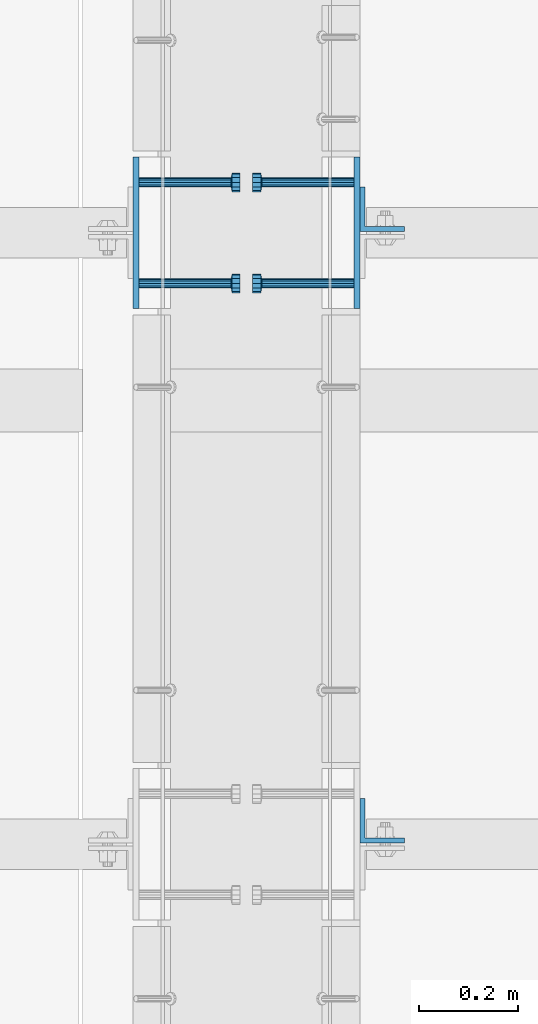
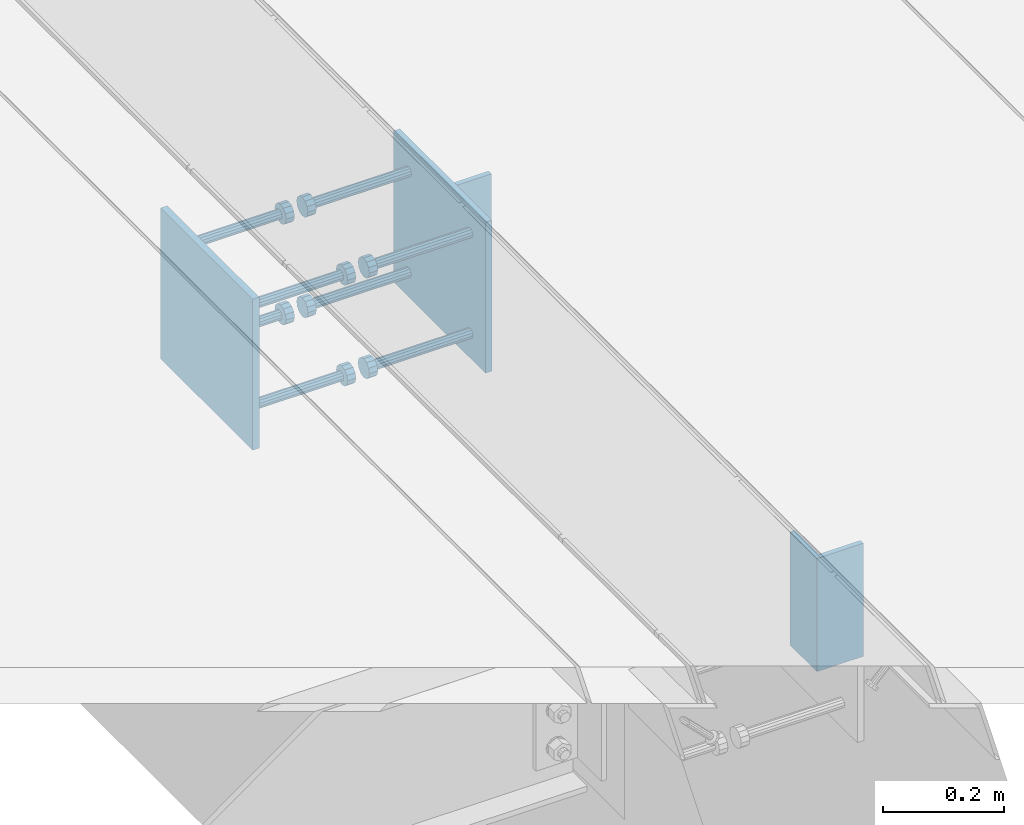
# One storey, part 2082 of 3843: 12 beams, 4 elements without a shape of their own.
"""IFC2X3 building model written with IfcOpenShell, lengths in millimetres."""

from ifc_helpers import new_model, si_unit, frame, origin_with_axes, place, context, subcontext, project, spatial, faceted_brep, material, type_object, element, aggregate, save


model = new_model("IFC2X3")

# Units and contexts
model_context = context("Model", 3, precision=1e-05, world=origin_with_axes())
body_context = subcontext(model_context, "Body", "Model", "MODEL_VIEW")
ifc_project = project(units=[si_unit("LENGTHUNIT", "METRE", prefix="MILLI"), si_unit("AREAUNIT", "SQUARE_METRE"), si_unit("VOLUMEUNIT", "CUBIC_METRE"), si_unit("MASSUNIT", "GRAM", prefix="KILO"), si_unit("TIMEUNIT", "SECOND"), si_unit("PLANEANGLEUNIT", "RADIAN"), si_unit("SOLIDANGLEUNIT", "STERADIAN"), si_unit("THERMODYNAMICTEMPERATUREUNIT", "DEGREE_CELSIUS"), si_unit("LUMINOUSINTENSITYUNIT", "LUMEN")], contexts=[model_context])

# Site, building, storey
site_placement = place(None, origin_with_axes())
site = spatial("IfcSite", under=ifc_project, at=site_placement, CompositionType="ELEMENT")
building_placement = place(site_placement, origin_with_axes())
building = spatial("IfcBuilding", under=site, at=building_placement, Name="Undefined", CompositionType="ELEMENT")
storey_placement = place(building_placement, origin_with_axes())
storey = spatial("IfcBuildingStorey", under=building, at=storey_placement, Name="Undefined", CompositionType="ELEMENT", Elevation=0.0)

# Assembly, beam
assembly_1_placement = place(storey_placement, origin_with_axes())
assembly_1 = element("IfcElementAssembly", 1, at=assembly_1_placement, inside=storey, Name="EMBED PLATE", AssemblyPlace="NOTDEFINED", PredefinedType="RIGID_FRAME")
ifc_material_1 = material(Name="STEEL/A36")
beam_type_1 = type_object("IfcBeamType", PredefinedType="NOTDEFINED")
beam_1_placement = place(assembly_1_placement, frame((58959.7499969482, 17459.325, 30422.85), z_axis=(0.0, -1.0, 0.0), x_axis=(0.0, 0.0, -1.0)))
beam_1 = element("IfcBeam", 2, at=beam_1_placement, type_object=beam_type_1, material=ifc_material_1, Name="EMBED PLATE", context=body_context, shape_type="Brep", body=[
    faceted_brep([(-1.0550138540566e-10, 6.34999999999854, -152.400000000664), (1.0550138540566e-10, 6.34999999999854, 152.400000000656), (304.799999999999, 6.34999999999854, 152.400000000001), (304.799999999999, 6.34999999999854, -152.400000000001), (1.0550138540566e-10, -6.34999999999854, 152.400000000656), (304.799999999999, -6.34999999999854, 152.400000000001), (-1.0550138540566e-10, -6.34999999999854, -152.400000000664), (304.799999999999, -6.34999999999854, -152.400000000001)], [[[0, 1, 2, 3]], [[1, 4, 5, 2]], [[4, 6, 7, 5]], [[6, 0, 3, 7]], [[5, 7, 3, 2]], [[6, 4, 1, 0]]]),
])

assembly_2_placement = place(storey_placement, origin_with_axes())
assembly_2 = element("IfcElementAssembly", 3, at=assembly_2_placement, inside=storey, Name="EMBED PLATE", AssemblyPlace="NOTDEFINED", PredefinedType="RIGID_FRAME")
beam_2_placement = place(assembly_2_placement, frame((59404.2500030518, 17459.325, 30422.85), z_axis=(0.0, 1.0, 0.0), x_axis=(0.0, 0.0, -1.0)))
beam_2 = element("IfcBeam", 4, at=beam_2_placement, type_object=beam_type_1, material=ifc_material_1, Name="EMBED PLATE", context=body_context, shape_type="Brep", body=[
    faceted_brep([(-1.0550138540566e-10, 6.34999999999854, -152.400000000664), (1.0550138540566e-10, 6.34999999999854, 152.400000000656), (304.799999999999, 6.34999999999854, 152.400000000001), (304.799999999999, 6.34999999999854, -152.400000000001), (1.0550138540566e-10, -6.34999999999854, 152.400000000656), (304.799999999999, -6.34999999999854, 152.400000000001), (-1.0550138540566e-10, -6.34999999999854, -152.400000000664), (304.799999999999, -6.34999999999854, -152.400000000001)], [[[0, 1, 2, 3]], [[1, 4, 5, 2]], [[4, 6, 7, 5]], [[6, 0, 3, 7]], [[5, 7, 3, 2]], [[6, 4, 1, 0]]]),
])

assembly_3_placement = place(storey_placement, origin_with_axes())
assembly_3 = element("IfcElementAssembly", 5, at=assembly_3_placement, inside=storey, Name="BEAM", AssemblyPlace="NOTDEFINED", PredefinedType="RIGID_FRAME")
beam_type_2 = type_object("IfcBeamType", Name="L3-1/2X3-1/2X3/8", PredefinedType="NOTDEFINED")
beam_3_placement = place(assembly_3_placement, frame((59455.0500030518, 16276.6375, 30391.1), z_axis=(0.0, 1.0, 0.0), x_axis=(0.0, 0.0, -1.0)))
beam_3 = element("IfcBeam", 6, at=beam_3_placement, type_object=beam_type_2, material=ifc_material_1, Name="ANGLE", ObjectType="L3-1/2X3-1/2X3/8", context=body_context, shape_type="Brep", body=[
    faceted_brep([(-3.63797880709171e-12, 44.4499999999971, -44.4500000000007), (-3.63797880709171e-12, 44.4499999999971, 44.4500000000007), (228.600000000006, 44.4499999999971, 44.4500000000007), (228.600000000006, 44.4499999999971, -44.4500000000007), (0.0, 34.9250000000029, 44.4500000000007), (228.600000000006, 34.9250000000029, 44.4500000000007), (0.0, 34.9250000000029, -34.9250000000029), (228.600000000006, 34.9250000000029, -34.9249999999993), (0.0, -44.4499999999971, -34.9249999999993), (228.600000000006, -44.4499999999971, -34.9249999999993), (3.63797880709171e-12, -44.4499999999971, -44.4500000000007), (228.600000000006, -44.4499999999971, -44.4500000000007)], [[[0, 1, 2, 3]], [[1, 4, 5, 2]], [[4, 6, 7, 5]], [[6, 8, 9, 7]], [[8, 10, 11, 9]], [[10, 0, 3, 11]], [[5, 7, 9, 11, 3, 2]], [[10, 8, 6, 4, 1, 0]]]),
])
aggregate(assembly_3, [beam_3])

assembly_4_placement = place(storey_placement, origin_with_axes())
assembly_4 = element("IfcElementAssembly", 7, at=assembly_4_placement, inside=storey, Name="BEAM", AssemblyPlace="NOTDEFINED", PredefinedType="RIGID_FRAME")
beam_4_placement = place(assembly_4_placement, frame((59455.0500030518, 17506.95, 30391.1), z_axis=(0.0, 1.0, 0.0), x_axis=(0.0, 0.0, -1.0)))
beam_4 = element("IfcBeam", 8, at=beam_4_placement, type_object=beam_type_2, material=ifc_material_1, Name="ANGLE", ObjectType="L3-1/2X3-1/2X3/8", context=body_context, shape_type="Brep", body=[
    faceted_brep([(-3.63797880709171e-12, 44.4499999999971, -44.4500000000007), (-3.63797880709171e-12, 44.4499999999971, 44.4500000000007), (228.600000000006, 44.4499999999971, 44.4500000000007), (228.600000000006, 44.4499999999971, -44.4500000000007), (0.0, 34.9250000000029, 44.4500000000007), (228.600000000006, 34.9250000000029, 44.4500000000007), (0.0, 34.9250000000029, -34.9250000000029), (228.600000000006, 34.9250000000029, -34.9249999999993), (0.0, -44.4499999999971, -34.9249999999993), (228.600000000006, -44.4499999999971, -34.9249999999993), (3.63797880709171e-12, -44.4499999999971, -44.4500000000007), (228.600000000006, -44.4499999999971, -44.4500000000007)], [[[0, 1, 2, 3]], [[1, 4, 5, 2]], [[4, 6, 7, 5]], [[6, 8, 9, 7]], [[8, 10, 11, 9]], [[10, 0, 3, 11]], [[5, 7, 9, 11, 3, 2]], [[10, 8, 6, 4, 1, 0]]]),
])
aggregate(assembly_4, [beam_4])

# Beam
ifc_material_2 = material(Name="STEEL/A108")
beam_type_3 = type_object("IfcBeamType", PredefinedType="NOTDEFINED")
beam_5_placement = place(assembly_1_placement, frame((58966.0999969482, 17560.925, 30372.05), z_axis=(0.0, 1.0, 0.0), x_axis=(1.0, 0.0, 0.0)))
beam_5 = element("IfcBeam", 9, at=beam_5_placement, type_object=beam_type_3, material=ifc_material_2, Name="HEADED STUD ANCHOR", context=body_context, shape_type="Brep", body=[
    faceted_brep([(0.0, -9.52000045776367, 0.0), (0.0, -8.25, -4.76000022888184), (184.912000000004, -8.25, -4.76000022888184), (184.912000000004, -9.52000045776367, 0.0), (0.0, -4.76000022888184, -8.25), (184.912000000004, -4.76000022888184, -8.25), (0.0, 0.0, -9.52000045776367), (184.912000000004, 0.0, -9.52000045776367), (0.0, 4.76000022888184, -8.25), (184.912000000004, 4.76000022888184, -8.25), (0.0, 8.25, -4.76000022888184), (184.912000000004, 8.25, -4.76000022888184), (0.0, 9.52000045776367, 0.0), (184.912000000004, 9.52000045776367, 0.0), (0.0, 8.25, 4.76000022888184), (184.912000000004, 8.25, 4.76000022888184), (0.0, 4.76000022888184, 8.25), (184.912000000004, 4.76000022888184, 8.25), (0.0, 0.0, 9.52000045776367), (184.912000000004, 0.0, 9.52000045776367), (0.0, -4.76000022888184, 8.25), (184.912000000004, -4.76000022888184, 8.25), (0.0, -8.25, 4.76000022888184), (184.912000000004, -8.25, 4.76000022888184), (186.944000000003, -16.5, -9.52000045776367), (186.944000000003, -19.0499992370605, 0.0), (186.944000000003, -9.52000045776367, -16.5), (186.944000000003, 0.0, -19.0499992370605), (186.944000000003, 9.52000045776367, -16.5), (186.944000000003, 16.5, -9.52000045776367), (186.944000000003, 19.0499992370605, 0.0), (186.944000000003, 16.5, 9.52000045776367), (186.944000000003, 9.52000045776367, 16.5), (186.944000000003, 0.0, 19.0499992370605), (186.944000000003, -9.52000045776367, 16.5), (186.944000000003, -16.5, 9.52000045776367), (203.199999999997, -16.5, -9.52000045776367), (203.199999999997, -19.0499992370605, 0.0), (203.199999999997, -9.52000045776367, -16.5), (203.199999999997, 0.0, -19.0499992370605), (203.199999999997, 9.52000045776367, -16.5), (203.199999999997, 16.5, -9.52000045776367), (203.199999999997, 19.0499992370605, 0.0), (203.199999999997, 16.5, 9.52000045776367), (203.199999999997, 9.52000045776367, 16.5), (203.199999999997, 0.0, 19.0499992370605), (203.199999999997, -9.52000045776367, 16.5), (203.199999999997, -16.5, 9.52000045776367)], [[[0, 1, 2, 3]], [[1, 4, 5, 2]], [[4, 6, 7, 5]], [[6, 8, 9, 7]], [[8, 10, 11, 9]], [[10, 12, 13, 11]], [[12, 14, 15, 13]], [[14, 16, 17, 15]], [[16, 18, 19, 17]], [[18, 20, 21, 19]], [[20, 22, 23, 21]], [[22, 0, 3, 23]], [[22, 20, 18, 16, 14, 12, 10, 8, 6, 4, 1, 0]], [[3, 2, 24, 25]], [[2, 5, 26, 24]], [[5, 7, 27, 26]], [[7, 9, 28, 27]], [[9, 11, 29, 28]], [[11, 13, 30, 29]], [[13, 15, 31, 30]], [[15, 17, 32, 31]], [[17, 19, 33, 32]], [[19, 21, 34, 33]], [[21, 23, 35, 34]], [[23, 3, 25, 35]], [[25, 24, 36, 37]], [[24, 26, 38, 36]], [[26, 27, 39, 38]], [[27, 28, 40, 39]], [[28, 29, 41, 40]], [[29, 30, 42, 41]], [[30, 31, 43, 42]], [[31, 32, 44, 43]], [[32, 33, 45, 44]], [[33, 34, 46, 45]], [[34, 35, 47, 46]], [[35, 25, 37, 47]], [[38, 39, 40, 41, 42, 43, 44, 45, 46, 47, 37, 36]]]),
])

beam_6_placement = place(assembly_1_placement, frame((58966.0999969482, 17560.925, 30168.85), z_axis=(0.0, 1.0, 0.0), x_axis=(1.0, 0.0, 0.0)))
beam_6 = element("IfcBeam", 10, at=beam_6_placement, type_object=beam_type_3, material=ifc_material_2, Name="HEADED STUD ANCHOR", context=body_context, shape_type="Brep", body=[
    faceted_brep([(0.0, -9.52000045776367, 0.0), (0.0, -8.25, -4.76000022888184), (184.912000000004, -8.25, -4.76000022888184), (184.912000000004, -9.52000045776367, 0.0), (0.0, -4.76000022888184, -8.25), (184.912000000004, -4.76000022888184, -8.25), (0.0, 0.0, -9.52000045776367), (184.912000000004, 0.0, -9.52000045776367), (0.0, 4.76000022888184, -8.25), (184.912000000004, 4.76000022888184, -8.25), (0.0, 8.25, -4.76000022888184), (184.912000000004, 8.25, -4.76000022888184), (0.0, 9.52000045776367, 0.0), (184.912000000004, 9.52000045776367, 0.0), (0.0, 8.25, 4.76000022888184), (184.912000000004, 8.25, 4.76000022888184), (0.0, 4.76000022888184, 8.25), (184.912000000004, 4.76000022888184, 8.25), (0.0, 0.0, 9.52000045776367), (184.912000000004, 0.0, 9.52000045776367), (0.0, -4.76000022888184, 8.25), (184.912000000004, -4.76000022888184, 8.25), (0.0, -8.25, 4.76000022888184), (184.912000000004, -8.25, 4.76000022888184), (186.944000000003, -16.5, -9.52000045776367), (186.944000000003, -19.0499992370605, 0.0), (186.944000000003, -9.52000045776367, -16.5), (186.944000000003, 0.0, -19.0499992370605), (186.944000000003, 9.52000045776367, -16.5), (186.944000000003, 16.5, -9.52000045776367), (186.944000000003, 19.0499992370605, 0.0), (186.944000000003, 16.5, 9.52000045776367), (186.944000000003, 9.52000045776367, 16.5), (186.944000000003, 0.0, 19.0499992370605), (186.944000000003, -9.52000045776367, 16.5), (186.944000000003, -16.5, 9.52000045776367), (203.199999999997, -16.5, -9.52000045776367), (203.199999999997, -19.0499992370605, 0.0), (203.199999999997, -9.52000045776367, -16.5), (203.199999999997, 0.0, -19.0499992370605), (203.199999999997, 9.52000045776367, -16.5), (203.199999999997, 16.5, -9.52000045776367), (203.199999999997, 19.0499992370605, 0.0), (203.199999999997, 16.5, 9.52000045776367), (203.199999999997, 9.52000045776367, 16.5), (203.199999999997, 0.0, 19.0499992370605), (203.199999999997, -9.52000045776367, 16.5), (203.199999999997, -16.5, 9.52000045776367)], [[[0, 1, 2, 3]], [[1, 4, 5, 2]], [[4, 6, 7, 5]], [[6, 8, 9, 7]], [[8, 10, 11, 9]], [[10, 12, 13, 11]], [[12, 14, 15, 13]], [[14, 16, 17, 15]], [[16, 18, 19, 17]], [[18, 20, 21, 19]], [[20, 22, 23, 21]], [[22, 0, 3, 23]], [[22, 20, 18, 16, 14, 12, 10, 8, 6, 4, 1, 0]], [[3, 2, 24, 25]], [[2, 5, 26, 24]], [[5, 7, 27, 26]], [[7, 9, 28, 27]], [[9, 11, 29, 28]], [[11, 13, 30, 29]], [[13, 15, 31, 30]], [[15, 17, 32, 31]], [[17, 19, 33, 32]], [[19, 21, 34, 33]], [[21, 23, 35, 34]], [[23, 3, 25, 35]], [[25, 24, 36, 37]], [[24, 26, 38, 36]], [[26, 27, 39, 38]], [[27, 28, 40, 39]], [[28, 29, 41, 40]], [[29, 30, 42, 41]], [[30, 31, 43, 42]], [[31, 32, 44, 43]], [[32, 33, 45, 44]], [[33, 34, 46, 45]], [[34, 35, 47, 46]], [[35, 25, 37, 47]], [[38, 39, 40, 41, 42, 43, 44, 45, 46, 47, 37, 36]]]),
])

beam_7_placement = place(assembly_1_placement, frame((58966.0999969482, 17357.725, 30372.05), z_axis=(0.0, 1.0, 0.0), x_axis=(1.0, 0.0, 0.0)))
beam_7 = element("IfcBeam", 11, at=beam_7_placement, type_object=beam_type_3, material=ifc_material_1, Name="PLATE", context=body_context, shape_type="Brep", body=[
    faceted_brep([(0.0, -9.52000045776367, 0.0), (0.0, -8.25, -4.76000022888184), (184.912000000004, -8.25, -4.76000022888184), (184.912000000004, -9.52000045776367, 0.0), (0.0, -4.76000022888184, -8.25), (184.912000000004, -4.76000022888184, -8.25), (0.0, 0.0, -9.52000045776367), (184.912000000004, 0.0, -9.52000045776367), (0.0, 4.76000022888184, -8.25), (184.912000000004, 4.76000022888184, -8.25), (0.0, 8.25, -4.76000022888184), (184.912000000004, 8.25, -4.76000022888184), (0.0, 9.52000045776367, 0.0), (184.912000000004, 9.52000045776367, 0.0), (0.0, 8.25, 4.76000022888184), (184.912000000004, 8.25, 4.76000022888184), (0.0, 4.76000022888184, 8.25), (184.912000000004, 4.76000022888184, 8.25), (0.0, 0.0, 9.52000045776367), (184.912000000004, 0.0, 9.52000045776367), (0.0, -4.76000022888184, 8.25), (184.912000000004, -4.76000022888184, 8.25), (0.0, -8.25, 4.76000022888184), (184.912000000004, -8.25, 4.76000022888184), (186.944000000003, -16.5, -9.52000045776367), (186.944000000003, -19.0499992370605, 0.0), (186.944000000003, -9.52000045776367, -16.5), (186.944000000003, 0.0, -19.0499992370605), (186.944000000003, 9.52000045776367, -16.5), (186.944000000003, 16.5, -9.52000045776367), (186.944000000003, 19.0499992370605, 0.0), (186.944000000003, 16.5, 9.52000045776367), (186.944000000003, 9.52000045776367, 16.5), (186.944000000003, 0.0, 19.0499992370605), (186.944000000003, -9.52000045776367, 16.5), (186.944000000003, -16.5, 9.52000045776367), (203.199999999997, -16.5, -9.52000045776367), (203.199999999997, -19.0499992370605, 0.0), (203.199999999997, -9.52000045776367, -16.5), (203.199999999997, 0.0, -19.0499992370605), (203.199999999997, 9.52000045776367, -16.5), (203.199999999997, 16.5, -9.52000045776367), (203.199999999997, 19.0499992370605, 0.0), (203.199999999997, 16.5, 9.52000045776367), (203.199999999997, 9.52000045776367, 16.5), (203.199999999997, 0.0, 19.0499992370605), (203.199999999997, -9.52000045776367, 16.5), (203.199999999997, -16.5, 9.52000045776367)], [[[0, 1, 2, 3]], [[1, 4, 5, 2]], [[4, 6, 7, 5]], [[6, 8, 9, 7]], [[8, 10, 11, 9]], [[10, 12, 13, 11]], [[12, 14, 15, 13]], [[14, 16, 17, 15]], [[16, 18, 19, 17]], [[18, 20, 21, 19]], [[20, 22, 23, 21]], [[22, 0, 3, 23]], [[22, 20, 18, 16, 14, 12, 10, 8, 6, 4, 1, 0]], [[3, 2, 24, 25]], [[2, 5, 26, 24]], [[5, 7, 27, 26]], [[7, 9, 28, 27]], [[9, 11, 29, 28]], [[11, 13, 30, 29]], [[13, 15, 31, 30]], [[15, 17, 32, 31]], [[17, 19, 33, 32]], [[19, 21, 34, 33]], [[21, 23, 35, 34]], [[23, 3, 25, 35]], [[25, 24, 36, 37]], [[24, 26, 38, 36]], [[26, 27, 39, 38]], [[27, 28, 40, 39]], [[28, 29, 41, 40]], [[29, 30, 42, 41]], [[30, 31, 43, 42]], [[31, 32, 44, 43]], [[32, 33, 45, 44]], [[33, 34, 46, 45]], [[34, 35, 47, 46]], [[35, 25, 37, 47]], [[38, 39, 40, 41, 42, 43, 44, 45, 46, 47, 37, 36]]]),
])

beam_8_placement = place(assembly_1_placement, frame((58966.0999969482, 17357.725, 30168.85), z_axis=(0.0, 1.0, 0.0), x_axis=(1.0, 0.0, 0.0)))
beam_8 = element("IfcBeam", 12, at=beam_8_placement, type_object=beam_type_3, material=ifc_material_2, Name="HEADED STUD ANCHOR", context=body_context, shape_type="Brep", body=[
    faceted_brep([(0.0, -9.52000045776367, 0.0), (0.0, -8.25, -4.76000022888184), (184.912000000004, -8.25, -4.76000022888184), (184.912000000004, -9.52000045776367, 0.0), (0.0, -4.76000022888184, -8.25), (184.912000000004, -4.76000022888184, -8.25), (0.0, 0.0, -9.52000045776367), (184.912000000004, 0.0, -9.52000045776367), (0.0, 4.76000022888184, -8.25), (184.912000000004, 4.76000022888184, -8.25), (0.0, 8.25, -4.76000022888184), (184.912000000004, 8.25, -4.76000022888184), (0.0, 9.52000045776367, 0.0), (184.912000000004, 9.52000045776367, 0.0), (0.0, 8.25, 4.76000022888184), (184.912000000004, 8.25, 4.76000022888184), (0.0, 4.76000022888184, 8.25), (184.912000000004, 4.76000022888184, 8.25), (0.0, 0.0, 9.52000045776367), (184.912000000004, 0.0, 9.52000045776367), (0.0, -4.76000022888184, 8.25), (184.912000000004, -4.76000022888184, 8.25), (0.0, -8.25, 4.76000022888184), (184.912000000004, -8.25, 4.76000022888184), (186.944000000003, -16.5, -9.52000045776367), (186.944000000003, -19.0499992370605, 0.0), (186.944000000003, -9.52000045776367, -16.5), (186.944000000003, 0.0, -19.0499992370605), (186.944000000003, 9.52000045776367, -16.5), (186.944000000003, 16.5, -9.52000045776367), (186.944000000003, 19.0499992370605, 0.0), (186.944000000003, 16.5, 9.52000045776367), (186.944000000003, 9.52000045776367, 16.5), (186.944000000003, 0.0, 19.0499992370605), (186.944000000003, -9.52000045776367, 16.5), (186.944000000003, -16.5, 9.52000045776367), (203.199999999997, -16.5, -9.52000045776367), (203.199999999997, -19.0499992370605, 0.0), (203.199999999997, -9.52000045776367, -16.5), (203.199999999997, 0.0, -19.0499992370605), (203.199999999997, 9.52000045776367, -16.5), (203.199999999997, 16.5, -9.52000045776367), (203.199999999997, 19.0499992370605, 0.0), (203.199999999997, 16.5, 9.52000045776367), (203.199999999997, 9.52000045776367, 16.5), (203.199999999997, 0.0, 19.0499992370605), (203.199999999997, -9.52000045776367, 16.5), (203.199999999997, -16.5, 9.52000045776367)], [[[0, 1, 2, 3]], [[1, 4, 5, 2]], [[4, 6, 7, 5]], [[6, 8, 9, 7]], [[8, 10, 11, 9]], [[10, 12, 13, 11]], [[12, 14, 15, 13]], [[14, 16, 17, 15]], [[16, 18, 19, 17]], [[18, 20, 21, 19]], [[20, 22, 23, 21]], [[22, 0, 3, 23]], [[22, 20, 18, 16, 14, 12, 10, 8, 6, 4, 1, 0]], [[3, 2, 24, 25]], [[2, 5, 26, 24]], [[5, 7, 27, 26]], [[7, 9, 28, 27]], [[9, 11, 29, 28]], [[11, 13, 30, 29]], [[13, 15, 31, 30]], [[15, 17, 32, 31]], [[17, 19, 33, 32]], [[19, 21, 34, 33]], [[21, 23, 35, 34]], [[23, 3, 25, 35]], [[25, 24, 36, 37]], [[24, 26, 38, 36]], [[26, 27, 39, 38]], [[27, 28, 40, 39]], [[28, 29, 41, 40]], [[29, 30, 42, 41]], [[30, 31, 43, 42]], [[31, 32, 44, 43]], [[32, 33, 45, 44]], [[33, 34, 46, 45]], [[34, 35, 47, 46]], [[35, 25, 37, 47]], [[38, 39, 40, 41, 42, 43, 44, 45, 46, 47, 37, 36]]]),
])

aggregate(assembly_1, [beam_5, beam_6, beam_7, beam_8, beam_1])

beam_9_placement = place(assembly_2_placement, frame((59397.9000030518, 17357.725, 30372.05), z_axis=(0.0, -1.0, 0.0), x_axis=(-1.0, 0.0, 0.0)))
beam_9 = element("IfcBeam", 13, at=beam_9_placement, type_object=beam_type_3, material=ifc_material_2, Name="HEADED STUD ANCHOR", context=body_context, shape_type="Brep", body=[
    faceted_brep([(0.0, -9.52000045776367, 0.0), (0.0, -8.25, -4.76000022888184), (184.912000000004, -8.25, -4.76000022888184), (184.912000000004, -9.52000045776367, 0.0), (0.0, -4.76000022888184, -8.25), (184.912000000004, -4.76000022888184, -8.25), (0.0, 0.0, -9.52000045776367), (184.912000000004, 0.0, -9.52000045776367), (0.0, 4.76000022888184, -8.25), (184.912000000004, 4.76000022888184, -8.25), (0.0, 8.25, -4.76000022888184), (184.912000000004, 8.25, -4.76000022888184), (0.0, 9.52000045776367, 0.0), (184.912000000004, 9.52000045776367, 0.0), (0.0, 8.25, 4.76000022888184), (184.912000000004, 8.25, 4.76000022888184), (0.0, 4.76000022888184, 8.25), (184.912000000004, 4.76000022888184, 8.25), (0.0, 0.0, 9.52000045776367), (184.912000000004, 0.0, 9.52000045776367), (0.0, -4.76000022888184, 8.25), (184.912000000004, -4.76000022888184, 8.25), (0.0, -8.25, 4.76000022888184), (184.912000000004, -8.25, 4.76000022888184), (186.944000000003, -16.5, -9.52000045776367), (186.944000000003, -19.0499992370605, 0.0), (186.944000000003, -9.52000045776367, -16.5), (186.944000000003, 0.0, -19.0499992370605), (186.944000000003, 9.52000045776367, -16.5), (186.944000000003, 16.5, -9.52000045776367), (186.944000000003, 19.0499992370605, 0.0), (186.944000000003, 16.5, 9.52000045776367), (186.944000000003, 9.52000045776367, 16.5), (186.944000000003, 0.0, 19.0499992370605), (186.944000000003, -9.52000045776367, 16.5), (186.944000000003, -16.5, 9.52000045776367), (203.199999999997, -16.5, -9.52000045776367), (203.199999999997, -19.0499992370605, 0.0), (203.199999999997, -9.52000045776367, -16.5), (203.199999999997, 0.0, -19.0499992370605), (203.199999999997, 9.52000045776367, -16.5), (203.199999999997, 16.5, -9.52000045776367), (203.199999999997, 19.0499992370605, 0.0), (203.199999999997, 16.5, 9.52000045776367), (203.199999999997, 9.52000045776367, 16.5), (203.199999999997, 0.0, 19.0499992370605), (203.199999999997, -9.52000045776367, 16.5), (203.199999999997, -16.5, 9.52000045776367)], [[[0, 1, 2, 3]], [[1, 4, 5, 2]], [[4, 6, 7, 5]], [[6, 8, 9, 7]], [[8, 10, 11, 9]], [[10, 12, 13, 11]], [[12, 14, 15, 13]], [[14, 16, 17, 15]], [[16, 18, 19, 17]], [[18, 20, 21, 19]], [[20, 22, 23, 21]], [[22, 0, 3, 23]], [[22, 20, 18, 16, 14, 12, 10, 8, 6, 4, 1, 0]], [[3, 2, 24, 25]], [[2, 5, 26, 24]], [[5, 7, 27, 26]], [[7, 9, 28, 27]], [[9, 11, 29, 28]], [[11, 13, 30, 29]], [[13, 15, 31, 30]], [[15, 17, 32, 31]], [[17, 19, 33, 32]], [[19, 21, 34, 33]], [[21, 23, 35, 34]], [[23, 3, 25, 35]], [[25, 24, 36, 37]], [[24, 26, 38, 36]], [[26, 27, 39, 38]], [[27, 28, 40, 39]], [[28, 29, 41, 40]], [[29, 30, 42, 41]], [[30, 31, 43, 42]], [[31, 32, 44, 43]], [[32, 33, 45, 44]], [[33, 34, 46, 45]], [[34, 35, 47, 46]], [[35, 25, 37, 47]], [[38, 39, 40, 41, 42, 43, 44, 45, 46, 47, 37, 36]]]),
])

beam_10_placement = place(assembly_2_placement, frame((59397.9000030518, 17357.725, 30168.85), z_axis=(0.0, -1.0, 0.0), x_axis=(-1.0, 0.0, 0.0)))
beam_10 = element("IfcBeam", 14, at=beam_10_placement, type_object=beam_type_3, material=ifc_material_2, Name="HEADED STUD ANCHOR", context=body_context, shape_type="Brep", body=[
    faceted_brep([(0.0, -9.52000045776367, 0.0), (0.0, -8.25, -4.76000022888184), (184.912000000004, -8.25, -4.76000022888184), (184.912000000004, -9.52000045776367, 0.0), (0.0, -4.76000022888184, -8.25), (184.912000000004, -4.76000022888184, -8.25), (0.0, 0.0, -9.52000045776367), (184.912000000004, 0.0, -9.52000045776367), (0.0, 4.76000022888184, -8.25), (184.912000000004, 4.76000022888184, -8.25), (0.0, 8.25, -4.76000022888184), (184.912000000004, 8.25, -4.76000022888184), (0.0, 9.52000045776367, 0.0), (184.912000000004, 9.52000045776367, 0.0), (0.0, 8.25, 4.76000022888184), (184.912000000004, 8.25, 4.76000022888184), (0.0, 4.76000022888184, 8.25), (184.912000000004, 4.76000022888184, 8.25), (0.0, 0.0, 9.52000045776367), (184.912000000004, 0.0, 9.52000045776367), (0.0, -4.76000022888184, 8.25), (184.912000000004, -4.76000022888184, 8.25), (0.0, -8.25, 4.76000022888184), (184.912000000004, -8.25, 4.76000022888184), (186.944000000003, -16.5, -9.52000045776367), (186.944000000003, -19.0499992370605, 0.0), (186.944000000003, -9.52000045776367, -16.5), (186.944000000003, 0.0, -19.0499992370605), (186.944000000003, 9.52000045776367, -16.5), (186.944000000003, 16.5, -9.52000045776367), (186.944000000003, 19.0499992370605, 0.0), (186.944000000003, 16.5, 9.52000045776367), (186.944000000003, 9.52000045776367, 16.5), (186.944000000003, 0.0, 19.0499992370605), (186.944000000003, -9.52000045776367, 16.5), (186.944000000003, -16.5, 9.52000045776367), (203.199999999997, -16.5, -9.52000045776367), (203.199999999997, -19.0499992370605, 0.0), (203.199999999997, -9.52000045776367, -16.5), (203.199999999997, 0.0, -19.0499992370605), (203.199999999997, 9.52000045776367, -16.5), (203.199999999997, 16.5, -9.52000045776367), (203.199999999997, 19.0499992370605, 0.0), (203.199999999997, 16.5, 9.52000045776367), (203.199999999997, 9.52000045776367, 16.5), (203.199999999997, 0.0, 19.0499992370605), (203.199999999997, -9.52000045776367, 16.5), (203.199999999997, -16.5, 9.52000045776367)], [[[0, 1, 2, 3]], [[1, 4, 5, 2]], [[4, 6, 7, 5]], [[6, 8, 9, 7]], [[8, 10, 11, 9]], [[10, 12, 13, 11]], [[12, 14, 15, 13]], [[14, 16, 17, 15]], [[16, 18, 19, 17]], [[18, 20, 21, 19]], [[20, 22, 23, 21]], [[22, 0, 3, 23]], [[22, 20, 18, 16, 14, 12, 10, 8, 6, 4, 1, 0]], [[3, 2, 24, 25]], [[2, 5, 26, 24]], [[5, 7, 27, 26]], [[7, 9, 28, 27]], [[9, 11, 29, 28]], [[11, 13, 30, 29]], [[13, 15, 31, 30]], [[15, 17, 32, 31]], [[17, 19, 33, 32]], [[19, 21, 34, 33]], [[21, 23, 35, 34]], [[23, 3, 25, 35]], [[25, 24, 36, 37]], [[24, 26, 38, 36]], [[26, 27, 39, 38]], [[27, 28, 40, 39]], [[28, 29, 41, 40]], [[29, 30, 42, 41]], [[30, 31, 43, 42]], [[31, 32, 44, 43]], [[32, 33, 45, 44]], [[33, 34, 46, 45]], [[34, 35, 47, 46]], [[35, 25, 37, 47]], [[38, 39, 40, 41, 42, 43, 44, 45, 46, 47, 37, 36]]]),
])

beam_11_placement = place(assembly_2_placement, frame((59397.9000030518, 17560.925, 30372.05), z_axis=(0.0, -1.0, 0.0), x_axis=(-1.0, 0.0, 0.0)))
beam_11 = element("IfcBeam", 15, at=beam_11_placement, type_object=beam_type_3, material=ifc_material_1, Name="PLATE", context=body_context, shape_type="Brep", body=[
    faceted_brep([(0.0, -9.52000045776367, 0.0), (0.0, -8.25, -4.76000022888184), (184.912000000004, -8.25, -4.76000022888184), (184.912000000004, -9.52000045776367, 0.0), (0.0, -4.76000022888184, -8.25), (184.912000000004, -4.76000022888184, -8.25), (0.0, 0.0, -9.52000045776367), (184.912000000004, 0.0, -9.52000045776367), (0.0, 4.76000022888184, -8.25), (184.912000000004, 4.76000022888184, -8.25), (0.0, 8.25, -4.76000022888184), (184.912000000004, 8.25, -4.76000022888184), (0.0, 9.52000045776367, 0.0), (184.912000000004, 9.52000045776367, 0.0), (0.0, 8.25, 4.76000022888184), (184.912000000004, 8.25, 4.76000022888184), (0.0, 4.76000022888184, 8.25), (184.912000000004, 4.76000022888184, 8.25), (0.0, 0.0, 9.52000045776367), (184.912000000004, 0.0, 9.52000045776367), (0.0, -4.76000022888184, 8.25), (184.912000000004, -4.76000022888184, 8.25), (0.0, -8.25, 4.76000022888184), (184.912000000004, -8.25, 4.76000022888184), (186.944000000003, -16.5, -9.52000045776367), (186.944000000003, -19.0499992370605, 0.0), (186.944000000003, -9.52000045776367, -16.5), (186.944000000003, 0.0, -19.0499992370605), (186.944000000003, 9.52000045776367, -16.5), (186.944000000003, 16.5, -9.52000045776367), (186.944000000003, 19.0499992370605, 0.0), (186.944000000003, 16.5, 9.52000045776367), (186.944000000003, 9.52000045776367, 16.5), (186.944000000003, 0.0, 19.0499992370605), (186.944000000003, -9.52000045776367, 16.5), (186.944000000003, -16.5, 9.52000045776367), (203.199999999997, -16.5, -9.52000045776367), (203.199999999997, -19.0499992370605, 0.0), (203.199999999997, -9.52000045776367, -16.5), (203.199999999997, 0.0, -19.0499992370605), (203.199999999997, 9.52000045776367, -16.5), (203.199999999997, 16.5, -9.52000045776367), (203.199999999997, 19.0499992370605, 0.0), (203.199999999997, 16.5, 9.52000045776367), (203.199999999997, 9.52000045776367, 16.5), (203.199999999997, 0.0, 19.0499992370605), (203.199999999997, -9.52000045776367, 16.5), (203.199999999997, -16.5, 9.52000045776367)], [[[0, 1, 2, 3]], [[1, 4, 5, 2]], [[4, 6, 7, 5]], [[6, 8, 9, 7]], [[8, 10, 11, 9]], [[10, 12, 13, 11]], [[12, 14, 15, 13]], [[14, 16, 17, 15]], [[16, 18, 19, 17]], [[18, 20, 21, 19]], [[20, 22, 23, 21]], [[22, 0, 3, 23]], [[22, 20, 18, 16, 14, 12, 10, 8, 6, 4, 1, 0]], [[3, 2, 24, 25]], [[2, 5, 26, 24]], [[5, 7, 27, 26]], [[7, 9, 28, 27]], [[9, 11, 29, 28]], [[11, 13, 30, 29]], [[13, 15, 31, 30]], [[15, 17, 32, 31]], [[17, 19, 33, 32]], [[19, 21, 34, 33]], [[21, 23, 35, 34]], [[23, 3, 25, 35]], [[25, 24, 36, 37]], [[24, 26, 38, 36]], [[26, 27, 39, 38]], [[27, 28, 40, 39]], [[28, 29, 41, 40]], [[29, 30, 42, 41]], [[30, 31, 43, 42]], [[31, 32, 44, 43]], [[32, 33, 45, 44]], [[33, 34, 46, 45]], [[34, 35, 47, 46]], [[35, 25, 37, 47]], [[38, 39, 40, 41, 42, 43, 44, 45, 46, 47, 37, 36]]]),
])

beam_12_placement = place(assembly_2_placement, frame((59397.9000030518, 17560.925, 30168.85), z_axis=(0.0, -1.0, 0.0), x_axis=(-1.0, 0.0, 0.0)))
beam_12 = element("IfcBeam", 16, at=beam_12_placement, type_object=beam_type_3, material=ifc_material_2, Name="HEADED STUD ANCHOR", context=body_context, shape_type="Brep", body=[
    faceted_brep([(0.0, -9.52000045776367, 0.0), (0.0, -8.25, -4.76000022888184), (184.912000000004, -8.25, -4.76000022888184), (184.912000000004, -9.52000045776367, 0.0), (0.0, -4.76000022888184, -8.25), (184.912000000004, -4.76000022888184, -8.25), (0.0, 0.0, -9.52000045776367), (184.912000000004, 0.0, -9.52000045776367), (0.0, 4.76000022888184, -8.25), (184.912000000004, 4.76000022888184, -8.25), (0.0, 8.25, -4.76000022888184), (184.912000000004, 8.25, -4.76000022888184), (0.0, 9.52000045776367, 0.0), (184.912000000004, 9.52000045776367, 0.0), (0.0, 8.25, 4.76000022888184), (184.912000000004, 8.25, 4.76000022888184), (0.0, 4.76000022888184, 8.25), (184.912000000004, 4.76000022888184, 8.25), (0.0, 0.0, 9.52000045776367), (184.912000000004, 0.0, 9.52000045776367), (0.0, -4.76000022888184, 8.25), (184.912000000004, -4.76000022888184, 8.25), (0.0, -8.25, 4.76000022888184), (184.912000000004, -8.25, 4.76000022888184), (186.944000000003, -16.5, -9.52000045776367), (186.944000000003, -19.0499992370605, 0.0), (186.944000000003, -9.52000045776367, -16.5), (186.944000000003, 0.0, -19.0499992370605), (186.944000000003, 9.52000045776367, -16.5), (186.944000000003, 16.5, -9.52000045776367), (186.944000000003, 19.0499992370605, 0.0), (186.944000000003, 16.5, 9.52000045776367), (186.944000000003, 9.52000045776367, 16.5), (186.944000000003, 0.0, 19.0499992370605), (186.944000000003, -9.52000045776367, 16.5), (186.944000000003, -16.5, 9.52000045776367), (203.199999999997, -16.5, -9.52000045776367), (203.199999999997, -19.0499992370605, 0.0), (203.199999999997, -9.52000045776367, -16.5), (203.199999999997, 0.0, -19.0499992370605), (203.199999999997, 9.52000045776367, -16.5), (203.199999999997, 16.5, -9.52000045776367), (203.199999999997, 19.0499992370605, 0.0), (203.199999999997, 16.5, 9.52000045776367), (203.199999999997, 9.52000045776367, 16.5), (203.199999999997, 0.0, 19.0499992370605), (203.199999999997, -9.52000045776367, 16.5), (203.199999999997, -16.5, 9.52000045776367)], [[[0, 1, 2, 3]], [[1, 4, 5, 2]], [[4, 6, 7, 5]], [[6, 8, 9, 7]], [[8, 10, 11, 9]], [[10, 12, 13, 11]], [[12, 14, 15, 13]], [[14, 16, 17, 15]], [[16, 18, 19, 17]], [[18, 20, 21, 19]], [[20, 22, 23, 21]], [[22, 0, 3, 23]], [[22, 20, 18, 16, 14, 12, 10, 8, 6, 4, 1, 0]], [[3, 2, 24, 25]], [[2, 5, 26, 24]], [[5, 7, 27, 26]], [[7, 9, 28, 27]], [[9, 11, 29, 28]], [[11, 13, 30, 29]], [[13, 15, 31, 30]], [[15, 17, 32, 31]], [[17, 19, 33, 32]], [[19, 21, 34, 33]], [[21, 23, 35, 34]], [[23, 3, 25, 35]], [[25, 24, 36, 37]], [[24, 26, 38, 36]], [[26, 27, 39, 38]], [[27, 28, 40, 39]], [[28, 29, 41, 40]], [[29, 30, 42, 41]], [[30, 31, 43, 42]], [[31, 32, 44, 43]], [[32, 33, 45, 44]], [[33, 34, 46, 45]], [[34, 35, 47, 46]], [[35, 25, 37, 47]], [[38, 39, 40, 41, 42, 43, 44, 45, 46, 47, 37, 36]]]),
])

aggregate(assembly_2, [beam_9, beam_10, beam_11, beam_12, beam_2])

save(model, "model.ifc")
